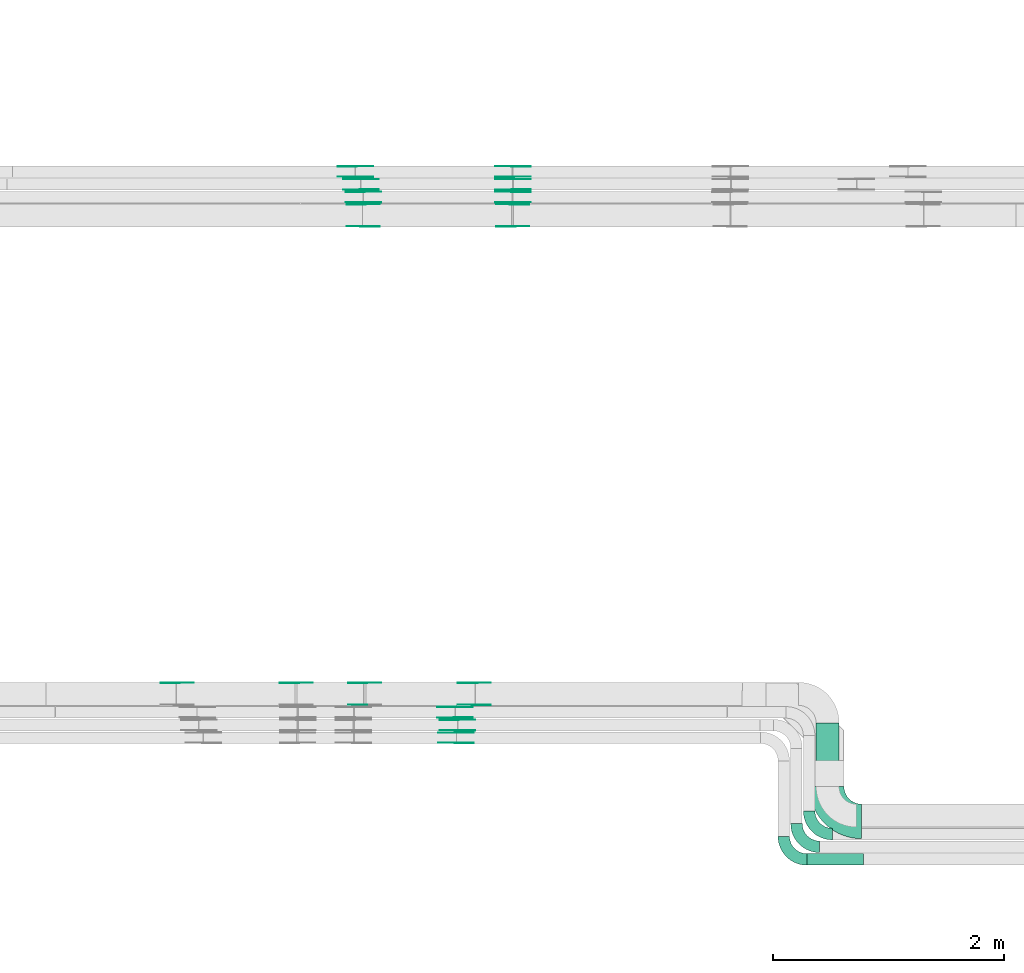
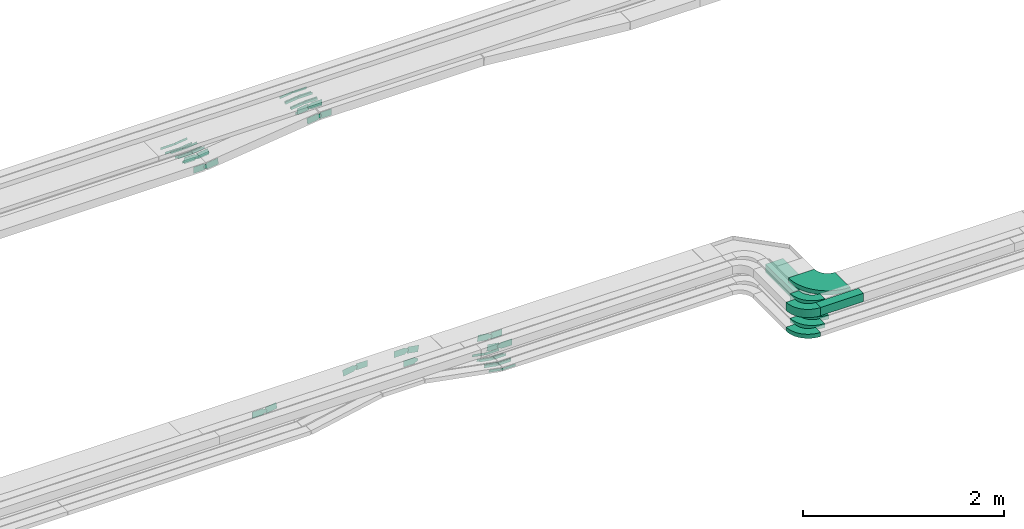
# One storey, part 22 of 33: 61 flow fittings, 2 flow segments.
"""IFC2X3 building model written with IfcOpenShell, lengths in millimetres."""

from ifc_helpers import new_model, entity, si_unit, converted_unit, derived_unit, direction, frame, frame_2d, origin, origin_2d_with_axis, place, context, subcontext, project, spatial, polyline, circle_curve, parameter, trimmed, segment, composite_curve, rectangle, outline, extrude, source, transform, mapped, material, type_object, type_shapes, element, save


model = new_model("IFC2X3")

# Units and contexts
model_context = context("Model", 3, precision=0.01, world=origin(), true_north=direction((6.12303176911189e-17, 1.0)))
body_context = subcontext(model_context, "Body", "Model", "MODEL_VIEW")
ifc_project = project(units=[si_unit("LENGTHUNIT", "METRE", prefix="MILLI"), si_unit("AREAUNIT", "SQUARE_METRE"), si_unit("VOLUMEUNIT", "CUBIC_METRE"), converted_unit("PLANEANGLEUNIT", "DEGREE", entity("IfcRatioMeasure", 0.0174532925199433), si_unit("PLANEANGLEUNIT", "RADIAN"), dimensions=[0, 0, 0, 0, 0, 0, 0]), si_unit("MASSUNIT", "GRAM", prefix="KILO"), derived_unit("MASSDENSITYUNIT", [(si_unit("MASSUNIT", "GRAM", prefix="KILO"), 1), (si_unit("LENGTHUNIT", "METRE"), -3)]), derived_unit("MOMENTOFINERTIAUNIT", [(si_unit("LENGTHUNIT", "METRE"), 4)]), si_unit("TIMEUNIT", "SECOND"), si_unit("FREQUENCYUNIT", "HERTZ"), si_unit("THERMODYNAMICTEMPERATUREUNIT", "DEGREE_CELSIUS"), derived_unit("THERMALTRANSMITTANCEUNIT", [(si_unit("MASSUNIT", "GRAM", prefix="KILO"), 1), (si_unit("THERMODYNAMICTEMPERATUREUNIT", "KELVIN"), -1), (si_unit("TIMEUNIT", "SECOND"), -3)]), derived_unit("VOLUMETRICFLOWRATEUNIT", [(si_unit("LENGTHUNIT", "METRE"), 3), (si_unit("TIMEUNIT", "SECOND"), -1)]), derived_unit("MASSFLOWRATEUNIT", [(si_unit("MASSUNIT", "GRAM", prefix="KILO"), 1), (si_unit("TIMEUNIT", "SECOND"), -1)]), derived_unit("ROTATIONALFREQUENCYUNIT", [(si_unit("TIMEUNIT", "SECOND"), -1)]), si_unit("ELECTRICCURRENTUNIT", "AMPERE"), si_unit("ELECTRICVOLTAGEUNIT", "VOLT"), si_unit("POWERUNIT", "WATT"), si_unit("FORCEUNIT", "NEWTON", prefix="KILO"), si_unit("ILLUMINANCEUNIT", "LUX"), si_unit("LUMINOUSFLUXUNIT", "LUMEN"), si_unit("LUMINOUSINTENSITYUNIT", "CANDELA"), derived_unit("USERDEFINED", [(si_unit("MASSUNIT", "GRAM", prefix="KILO"), -1), (si_unit("LENGTHUNIT", "METRE"), -2), (si_unit("TIMEUNIT", "SECOND"), 3), (si_unit("LUMINOUSFLUXUNIT", "LUMEN"), 1)]), derived_unit("LINEARVELOCITYUNIT", [(si_unit("LENGTHUNIT", "METRE"), 1), (si_unit("TIMEUNIT", "SECOND"), -1)]), si_unit("PRESSUREUNIT", "PASCAL"), derived_unit("USERDEFINED", [(si_unit("LENGTHUNIT", "METRE"), -2), (si_unit("MASSUNIT", "GRAM", prefix="KILO"), 1), (si_unit("TIMEUNIT", "SECOND"), -2)]), derived_unit("LINEARFORCEUNIT", [(si_unit("MASSUNIT", "GRAM", prefix="KILO"), 1), (si_unit("LENGTHUNIT", "METRE"), 1), (si_unit("TIMEUNIT", "SECOND"), -2), (si_unit("LENGTHUNIT", "METRE"), -1)]), derived_unit("PLANARFORCEUNIT", [(si_unit("MASSUNIT", "GRAM", prefix="KILO"), 1), (si_unit("LENGTHUNIT", "METRE"), 1), (si_unit("TIMEUNIT", "SECOND"), -2), (si_unit("LENGTHUNIT", "METRE"), -2)])], contexts=[model_context])

# Site, building, storey
site_placement = place(None, frame((0.0, -0.00077364408347762, 0.0)))
site = spatial("IfcSite", under=ifc_project, at=site_placement, CompositionType="ELEMENT")
building_placement = place(site_placement, origin())
building = spatial("IfcBuilding", under=site, at=building_placement, CompositionType="ELEMENT")
storey_placement = place(building_placement, frame((0.0, 0.0, 8100.0)))
storey = spatial("IfcBuildingStorey", under=building, at=storey_placement, CompositionType="ELEMENT", Elevation=8100.0)

# Flow segments
cable_carrier_segment_type = type_object("IfcCableCarrierSegmentType", PredefinedType="CABLETRAYSEGMENT")
flow_segment_1_placement = place(storey_placement, frame((55150.108534959, 9320.97860618819, 2549.83876380786)))
element("IfcFlowSegment", 1, at=flow_segment_1_placement, inside=storey, type_object=cable_carrier_segment_type, context=body_context, shape_type="SweptSolid", body=[
    extrude(rectangle(XDim=553.020769727205, YDim=200.000000000007, at=frame_2d((-1.10844666778576e-12, 0.0), x_axis=(1.0, 0.0))), frame((100.0, 276.510384863604, 0.0), z_axis=(0.0, 0.0, 1.0), x_axis=(0.0, 1.0, 0.0)), (0.0, 0.0, 1.0), 99.9999999999989),
])
flow_segment_2_placement = place(storey_placement, frame((55071.1085191337, 8639.97737136105, 2799.49164816939)))
element("IfcFlowSegment", 2, at=flow_segment_2_placement, inside=storey, type_object=cable_carrier_segment_type, context=body_context, shape_type="SweptSolid", body=[
    extrude(rectangle(XDim=489.621580336119, YDim=99.9999999999995, at=origin_2d_with_axis()), frame((244.810790168433, 50.0024377090797, 0.00129633967850395), z_axis=(3.16498725628962e-07, -2.43771475119288e-05, 1.0), x_axis=(-1.0, 0.0, 3.16498724808628e-07)), (0.0, 0.0, 1.0), 99.999999999998),
])

# Flow fittings
ifc_material_1 = material()
cable_carrier_fitting_type_1 = type_object("IfcCableCarrierFittingType", Name="470_DKC_S5_Variable Angle Elbow 0-45:-", PredefinedType="NOTDEFINED", material=ifc_material_1)
shared_shape_1 = source(origin(), body_context, "Body", "SweptSolid", [
    extrude(outline(composite_curve([segment(polyline([(-100.750000000001, -150.25), (-99.7499999999994, -150.25)]), True, "CONTINUOUS"), segment(trimmed(circle_curve(frame_2d((-99.7499999999997, 99.7499999999995), x_axis=(0.0, -1.0)), 250.0), [parameter(0.0)], [parameter(90.0000000000001)], True, "PARAMETER"), True, "CONTINUOUS"), segment(polyline([(150.25, 99.75), (150.25, 100.749999999999)]), True, "CONTINUOUS"), segment(polyline([(150.25, 100.749999999999), (50.25, 100.75)]), True, "CONTINUOUS"), segment(polyline([(50.25, 100.75), (50.25, 99.7499999999998)]), True, "CONTINUOUS"), segment(trimmed(circle_curve(frame_2d((-99.7499999999997, 99.7499999999995), x_axis=(0.0, -1.0)), 150.0), [parameter(0.0)], [parameter(90.0000000000001)], True, "PARAMETER"), False, "CONTINUOUS"), segment(polyline([(-99.7499999999994, -50.2500000000003), (-100.750000000001, -50.2500000000003)]), True, "CONTINUOUS"), segment(polyline([(-100.750000000001, -50.2500000000003), (-100.750000000001, -150.25)]), True, "CONTINUOUS")], self_intersect=False)), frame((-100.249999999991, 100.249999999992, -25.0)), (0.0, 0.0, 1.0), 49.9999999999997),
])
type_shapes(cable_carrier_fitting_type_1, [shared_shape_1])
for number, where, z_axis, x_axis, name in (
    (3, (55090.108534959, 8909.97860618824, 2574.87332137863), (0.0, 0.0, 1.0), (0.0, -1.0, 0.0), "470_DKC_S5_Variable Angle Elbow 0-45:-"),
    (4, (54980.108534959, 8799.97860618823, 2574.86934553524), (0.0, 0.0, 1.0), (0.0, -1.0, 0.0), "470_DKC_S5_Variable Angle Elbow 0-45:-"),
    (5, (54870.108534959, 8689.98005285079, 2573.15905189632), (0.0, 0.0, 1.0), (0.0, -1.0, 0.0), "470_DKC_S5_Variable Angle Elbow 0-45:-"),
):
    element("IfcFlowFitting", number, at=place(storey_placement, frame(where, z_axis=z_axis, x_axis=x_axis)), inside=storey, type_object=cable_carrier_fitting_type_1, material=ifc_material_1, Name=name, ObjectType="470_DKC_S5_Variable Angle Elbow 0-45:-", context=body_context, shape_type="MappedRepresentation", body=[
        mapped(shared_shape_1, transform((0.0, 0.0, 0.0), scale=1.0)),
    ])
ifc_material_2 = material(Name="G")
cable_carrier_fitting_type_2 = type_object("IfcCableCarrierFittingType", PredefinedType="NOTDEFINED", material=ifc_material_2)
shared_shape_2 = source(origin(), body_context, "Body", "SweptSolid", [
    extrude(outline(composite_curve([segment(trimmed(circle_curve(frame_2d((-44.5901162790698, 0.0), x_axis=(1.0, 0.0)), 12.5), [parameter(90.0000000000007)], [parameter(270.0)], True, "PARAMETER"), True, "CONTINUOUS"), segment(polyline([(-44.5901162790697, -12.5), (-33.0901162790698, -12.5)]), True, "CONTINUOUS"), segment(polyline([(-33.0901162790698, -12.5), (-31.2296511627907, -14.5)]), True, "CONTINUOUS"), segment(polyline([(-31.2296511627907, -14.5), (108.90988372093, -14.5)]), True, "CONTINUOUS"), segment(polyline([(108.90988372093, -14.5), (108.90988372093, 14.5)]), True, "CONTINUOUS"), segment(polyline([(108.90988372093, 14.5), (-31.2296511627907, 14.5)]), True, "CONTINUOUS"), segment(polyline([(-31.2296511627907, 14.5), (-33.0901162790698, 12.5)]), True, "CONTINUOUS"), segment(polyline([(-33.0901162790698, 12.5), (-44.5901162790699, 12.5)]), True, "CONTINUOUS")], self_intersect=False)), frame((44.5901162790698, 0.0, 0.0), z_axis=(0.0, 0.0, -1.0), x_axis=(1.0, 0.0, 0.0)), (0.0, 0.0, -1.0), 2.0),
])
type_shapes(cable_carrier_fitting_type_2, [shared_shape_2])
for number, where, z_axis, x_axis in (
    (6, (52019.5208098215, 10010.4593759256, 2574.8733213786), (0.0, 1.0, 0.0), (-0.98311633812243, 0.0, 0.182981599393884)),
    (7, (51155.4962064039, 14606.8182357371, 2573.86724903674), (0.0, -1.0, 0.0), (0.993566510793548, 0.0, 0.113250115362128)),
    (8, (51204.8808370864, 14587.7382357575, 2573.34838425104), (0.0, 1.0, 0.0), (-1.0, 0.0, 0.0)),
    (9, (51226.099251318, 14386.8182357372, 2573.879926104), (0.0, -1.0, 0.0), (0.992897734535639, 0.0, 0.118970957607288)),
    (10, (52520.9130823038, 14386.8182357372, 2729.02706365649), (0.0, -1.0, 0.0), (-0.992897734535639, 0.0, -0.118970957607288)),
    (11, (52520.9130823038, 14606.8182357371, 2729.50214316132), (0.0, -1.0, 0.0), (-0.993566510793548, 0.0, -0.113250115362128)),
    (12, (52522.9130823037, 14496.8182357372, 2729.0228574609), (0.0, -1.0, 0.0), (-0.993097003616873, 0.0, -0.117295956482691)),
    (13, (52040.1085349586, 9809.53937590527, 2575.03455757074), (0.0, -1.0, 0.0), (1.0, 0.0, -5.61945698194788e-05)),
    (14, (52030.1085349585, 9699.53937590527, 2573.32548188807), (0.0, -1.0, 0.0), (1.0, 0.0, -5.86021096785072e-05)),
):
    element("IfcFlowFitting", number, at=place(storey_placement, frame(where, z_axis=z_axis, x_axis=x_axis)), inside=storey, type_object=cable_carrier_fitting_type_2, material=ifc_material_2, context=body_context, shape_type="MappedRepresentation", body=[
        mapped(shared_shape_2, transform((0.0, 0.0, 0.0), scale=1.0)),
    ])
cable_carrier_fitting_type_3 = type_object("IfcCableCarrierFittingType", PredefinedType="NOTDEFINED", material=ifc_material_2)
shared_shape_3 = source(origin(), body_context, "Body", "SweptSolid", [
    extrude(outline(composite_curve([segment(trimmed(circle_curve(frame_2d((-44.5901162790697, 0.0), x_axis=(1.0, 0.0)), 12.5), [parameter(90.0000000000007)], [parameter(270.0)], True, "PARAMETER"), True, "CONTINUOUS"), segment(polyline([(-44.5901162790697, -12.5), (-33.0901162790697, -12.5)]), True, "CONTINUOUS"), segment(polyline([(-33.0901162790697, -12.5), (-31.2296511627907, -14.5)]), True, "CONTINUOUS"), segment(polyline([(-31.2296511627907, -14.5), (108.90988372093, -14.5)]), True, "CONTINUOUS"), segment(polyline([(108.90988372093, -14.5), (108.90988372093, 14.5)]), True, "CONTINUOUS"), segment(polyline([(108.90988372093, 14.5), (-31.2296511627907, 14.5)]), True, "CONTINUOUS"), segment(polyline([(-31.2296511627907, 14.5), (-33.0901162790698, 12.5)]), True, "CONTINUOUS"), segment(polyline([(-33.0901162790698, 12.5), (-44.5901162790699, 12.5)]), True, "CONTINUOUS")], self_intersect=False)), frame((44.5901162790697, 0.0, 0.0)), (0.0, 0.0, 1.0), 2.0),
])
type_shapes(cable_carrier_fitting_type_3, [shared_shape_3])
for number, where, z_axis, x_axis in (
    (15, (52019.5208098215, 9919.53937590525, 2574.8733213786), (0.0, -1.0, 0.0), (-0.98311633812243, 0.0, 0.182981599393884)),
    (16, (51155.4962064039, 14697.7382357574, 2573.86724903674), (0.0, 1.0, 0.0), (0.993566510793548, 0.0, 0.113250115362128)),
    (17, (51204.8808370864, 14496.8182357372, 2573.34838425103), (0.0, -1.0, 0.0), (-1.0, 0.0, 0.0)),
    (18, (51226.099251318, 14477.7382357575, 2573.87992610399), (0.0, 1.0, 0.0), (0.992897734535639, 0.0, 0.118970957607288)),
    (19, (52520.9130823038, 14477.7382357575, 2729.02706365649), (0.0, 1.0, 0.0), (-0.992897734535639, 0.0, -0.118970957607288)),
    (20, (52520.9130823038, 14697.7382357574, 2729.50214316132), (0.0, 1.0, 0.0), (-0.993566510793548, 0.0, -0.113250115362128)),
    (21, (52522.9130823037, 14587.7382357575, 2729.0228574609), (0.0, 1.0, 0.0), (-0.993097003616873, 0.0, -0.117295956482691)),
    (22, (52040.1085349586, 9900.45937592559, 2575.03455757074), (0.0, 1.0, 0.0), (1.0, 0.0, -5.61945698194788e-05)),
    (23, (52030.1085349585, 9790.45937592558, 2573.32548188807), (0.0, 1.0, 0.0), (1.0, 0.0, -5.86021096785072e-05)),
):
    element("IfcFlowFitting", number, at=place(storey_placement, frame(where, z_axis=z_axis, x_axis=x_axis)), inside=storey, type_object=cable_carrier_fitting_type_3, material=ifc_material_2, context=body_context, shape_type="MappedRepresentation", body=[
        mapped(shared_shape_3, transform((0.0, 0.0, 0.0), scale=1.0)),
    ])
cable_carrier_fitting_type_4 = type_object("IfcCableCarrierFittingType", PredefinedType="NOTDEFINED", material=ifc_material_2)
shared_shape_4 = source(origin(), body_context, "Body", "SweptSolid", [
    extrude(outline(composite_curve([segment(trimmed(circle_curve(frame_2d((-44.5901162790698, 0.0), x_axis=(1.0, 0.0)), 12.5), [parameter(90.0000000000007)], [parameter(270.0)], True, "PARAMETER"), True, "CONTINUOUS"), segment(polyline([(-44.5901162790697, -12.5), (-33.0901162790698, -12.5)]), True, "CONTINUOUS"), segment(polyline([(-33.0901162790698, -12.5), (-31.2296511627907, -14.5)]), True, "CONTINUOUS"), segment(polyline([(-31.2296511627907, -14.5), (108.90988372093, -14.5)]), True, "CONTINUOUS"), segment(polyline([(108.90988372093, -14.5), (108.90988372093, 14.5)]), True, "CONTINUOUS"), segment(polyline([(108.90988372093, 14.5), (-31.2296511627907, 14.5)]), True, "CONTINUOUS"), segment(polyline([(-31.2296511627907, 14.5), (-33.0901162790698, 12.5)]), True, "CONTINUOUS"), segment(polyline([(-33.0901162790698, 12.5), (-44.5901162790699, 12.5)]), True, "CONTINUOUS")], self_intersect=False)), frame((44.5901162790698, 0.0, 0.0), z_axis=(0.0, 0.0, -1.0), x_axis=(1.0, 0.0, 0.0)), (0.0, 0.0, -1.0), 2.0),
])
type_shapes(cable_carrier_fitting_type_4, [shared_shape_4])
for number, where, z_axis, x_axis in (
    (24, (52019.5208098215, 9921.53937590525, 2574.87332137861), (0.0, -1.0, 0.0), (1.0, 0.0, 0.0)),
    (25, (51155.4962064039, 14695.7382357574, 2573.86724903675), (0.0, 1.0, 0.0), (-1.0, 0.0, 0.0)),
    (26, (51204.8808370863, 14498.8182357372, 2573.34838425104), (0.0, -1.0, 0.0), (0.993097003616296, 0.0, 0.117295956487574)),
    (27, (51226.099251318, 14475.7382357575, 2573.879926104), (0.0, 1.0, 0.0), (-1.0, 0.0, 0.0)),
    (28, (52520.9130823038, 14475.7382357575, 2729.02706365649), (0.0, 1.0, 0.0), (1.0, 0.0, 0.0)),
    (29, (52520.9130823038, 14695.7382357574, 2729.50214316131), (0.0, 1.0, 0.0), (1.0, 0.0, 0.0)),
    (30, (52522.9130823037, 14585.7382357575, 2729.02285746089), (0.0, 1.0, 0.0), (1.0, 0.0, 0.0)),
    (31, (52040.1085349586, 9898.45937592559, 2575.03455757074), (0.0, 1.0, 0.0), (-0.983855320382267, 0.0, 0.178965663062799)),
    (32, (52030.1085349585, 9788.45937592558, 2573.32548188807), (0.0, 1.0, 0.0), (-0.983194962125338, 0.0, 0.182558665779952)),
):
    element("IfcFlowFitting", number, at=place(storey_placement, frame(where, z_axis=z_axis, x_axis=x_axis)), inside=storey, type_object=cable_carrier_fitting_type_4, material=ifc_material_2, context=body_context, shape_type="MappedRepresentation", body=[
        mapped(shared_shape_4, transform((0.0, 0.0, 0.0), scale=1.0)),
    ])
cable_carrier_fitting_type_5 = type_object("IfcCableCarrierFittingType", PredefinedType="NOTDEFINED", material=ifc_material_2)
shared_shape_5 = source(origin(), body_context, "Body", "SweptSolid", [
    extrude(outline(composite_curve([segment(trimmed(circle_curve(frame_2d((-44.5901162790697, 0.0), x_axis=(1.0, 0.0)), 12.5), [parameter(90.0000000000007)], [parameter(270.0)], True, "PARAMETER"), True, "CONTINUOUS"), segment(polyline([(-44.5901162790697, -12.5), (-33.0901162790697, -12.5)]), True, "CONTINUOUS"), segment(polyline([(-33.0901162790697, -12.5), (-31.2296511627907, -14.5)]), True, "CONTINUOUS"), segment(polyline([(-31.2296511627907, -14.5), (108.90988372093, -14.5)]), True, "CONTINUOUS"), segment(polyline([(108.90988372093, -14.5), (108.90988372093, 14.5)]), True, "CONTINUOUS"), segment(polyline([(108.90988372093, 14.5), (-31.2296511627907, 14.5)]), True, "CONTINUOUS"), segment(polyline([(-31.2296511627907, 14.5), (-33.0901162790698, 12.5)]), True, "CONTINUOUS"), segment(polyline([(-33.0901162790698, 12.5), (-44.5901162790699, 12.5)]), True, "CONTINUOUS")], self_intersect=False)), frame((44.5901162790697, 0.0, 0.0)), (0.0, 0.0, 1.0), 2.0),
])
type_shapes(cable_carrier_fitting_type_5, [shared_shape_5])
for number, where, z_axis, x_axis in (
    (33, (52019.5208098215, 10008.4593759256, 2574.87332137861), (0.0, 1.0, 0.0), (1.0, 0.0, 0.0)),
    (34, (51155.4962064039, 14608.8182357371, 2573.86724903675), (0.0, -1.0, 0.0), (-1.0, 0.0, 0.0)),
    (35, (51204.8808370863, 14585.7382357575, 2573.34838425104), (0.0, 1.0, 0.0), (0.993097003616296, 0.0, 0.117295956487574)),
    (36, (51226.099251318, 14388.8182357372, 2573.879926104), (0.0, -1.0, 0.0), (-1.0, 0.0, 0.0)),
    (37, (52520.9130823038, 14388.8182357372, 2729.02706365649), (0.0, -1.0, 0.0), (1.0, 0.0, 0.0)),
    (38, (52520.9130823038, 14608.8182357371, 2729.50214316131), (0.0, -1.0, 0.0), (1.0, 0.0, 0.0)),
    (39, (52522.9130823037, 14498.8182357372, 2729.02285746089), (0.0, -1.0, 0.0), (1.0, 0.0, 0.0)),
    (40, (52040.1085349586, 9811.53937590527, 2575.03455757075), (0.0, -1.0, 0.0), (-0.983855320382267, 0.0, 0.178965663062799)),
    (41, (52030.1085349585, 9701.53937590527, 2573.32548188807), (0.0, -1.0, 0.0), (-0.983194962125338, 0.0, 0.182558665779952)),
):
    element("IfcFlowFitting", number, at=place(storey_placement, frame(where, z_axis=z_axis, x_axis=x_axis)), inside=storey, type_object=cable_carrier_fitting_type_5, material=ifc_material_2, context=body_context, shape_type="MappedRepresentation", body=[
        mapped(shared_shape_5, transform((0.0, 0.0, 0.0), scale=1.0)),
    ])
cable_carrier_fitting_type_6 = type_object("IfcCableCarrierFittingType", PredefinedType="NOTDEFINED", material=ifc_material_2)
shared_shape_6 = source(origin(), body_context, "Body", "SweptSolid", [
    extrude(outline(composite_curve([segment(trimmed(circle_curve(frame_2d((-41.4651162790697, 0.0), x_axis=(1.0, 0.0)), 25.0), [parameter(90.0000000000007)], [parameter(270.0)], True, "PARAMETER"), True, "CONTINUOUS"), segment(polyline([(-41.4651162790697, -25.0), (-29.9651162790697, -25.0)]), True, "CONTINUOUS"), segment(polyline([(-29.9651162790697, -25.0), (-28.1046511627907, -38.5)]), True, "CONTINUOUS"), segment(polyline([(-28.1046511627907, -38.5), (99.5348837209303, -38.5)]), True, "CONTINUOUS"), segment(polyline([(99.5348837209303, -38.5), (99.5348837209303, 38.5)]), True, "CONTINUOUS"), segment(polyline([(99.5348837209303, 38.5), (-28.1046511627907, 38.5)]), True, "CONTINUOUS"), segment(polyline([(-28.1046511627907, 38.5), (-29.9651162790697, 25.0)]), True, "CONTINUOUS"), segment(polyline([(-29.9651162790697, 25.0), (-41.46511627907, 25.0)]), True, "CONTINUOUS")], self_intersect=False)), frame((41.4651162790697, 0.0, 0.0), z_axis=(0.0, 0.0, -1.0), x_axis=(1.0, 0.0, 0.0)), (0.0, 0.0, -1.0), 2.0),
])
type_shapes(cable_carrier_fitting_type_6, [shared_shape_6])
for number, where, z_axis, x_axis in (
    (42, (50645.658835578, 10220.4593759256, 2763.61173786447), (0.0, 1.0, 0.0), (1.0, 0.0, 0.0)),
    (43, (51233.9754297485, 10220.4593759256, 2763.61173786447), (0.0, 1.0, 0.0), (0.985679085688948, 0.0, -0.168631966232386)),
    (44, (51221.4706831692, 14179.0392263459, 2598.87698397098), (0.0, -1.0, 0.0), (0.992897734535631, 0.0, 0.118970957607356)),
    (45, (52520.9130823038, 14179.0392263459, 2754.57872565434), (0.0, -1.0, 0.0), (-0.992897734535631, 0.0, -0.118970957607356)),
    (46, (52190.1085349587, 10029.5393759052, 2600.03455757074), (0.0, -1.0, 0.0), (0.999999997952967, 0.0, -6.39848897058259e-05)),
):
    element("IfcFlowFitting", number, at=place(storey_placement, frame(where, z_axis=z_axis, x_axis=x_axis)), inside=storey, type_object=cable_carrier_fitting_type_6, material=ifc_material_2, context=body_context, shape_type="MappedRepresentation", body=[
        mapped(shared_shape_6, transform((0.0, 0.0, 0.0), scale=1.0)),
    ])
cable_carrier_fitting_type_7 = type_object("IfcCableCarrierFittingType", PredefinedType="NOTDEFINED", material=ifc_material_2)
shared_shape_7 = source(origin(), body_context, "Body", "SweptSolid", [
    extrude(outline(composite_curve([segment(trimmed(circle_curve(frame_2d((-41.4651162790697, 0.0), x_axis=(1.0, 0.0)), 25.0), [parameter(90.0000000000007)], [parameter(270.0)], True, "PARAMETER"), True, "CONTINUOUS"), segment(polyline([(-41.4651162790697, -25.0), (-29.9651162790697, -25.0)]), True, "CONTINUOUS"), segment(polyline([(-29.9651162790697, -25.0), (-28.1046511627907, -38.5)]), True, "CONTINUOUS"), segment(polyline([(-28.1046511627907, -38.5), (99.5348837209303, -38.5)]), True, "CONTINUOUS"), segment(polyline([(99.5348837209303, -38.5), (99.5348837209303, 38.5)]), True, "CONTINUOUS"), segment(polyline([(99.5348837209303, 38.5), (-28.1046511627907, 38.5)]), True, "CONTINUOUS"), segment(polyline([(-28.1046511627907, 38.5), (-29.9651162790697, 25.0)]), True, "CONTINUOUS"), segment(polyline([(-29.9651162790697, 25.0), (-41.46511627907, 25.0)]), True, "CONTINUOUS")], self_intersect=False)), frame((41.4651162790697, 0.0, 0.0)), (0.0, 0.0, 1.0), 2.0),
])
type_shapes(cable_carrier_fitting_type_7, [shared_shape_7])
for number, where, z_axis, x_axis in (
    (47, (49608.2757950546, 10220.4593759256, 2597.39498136106), (0.0, 1.0, 0.0), (0.987405642693208, 0.0, 0.15820902874872)),
    (48, (51221.4706831692, 14369.9592263662, 2598.87698397097), (0.0, 1.0, 0.0), (0.992897734535631, 0.0, 0.118970957607356)),
    (49, (52520.9130823038, 14369.9592263662, 2754.57872565435), (0.0, 1.0, 0.0), (-0.992897734535631, 0.0, -0.118970957607356)),
    (50, (52190.1085349587, 10220.4593759256, 2600.03455757074), (0.0, 1.0, 0.0), (0.999999997952967, 0.0, -6.39848897058259e-05)),
):
    element("IfcFlowFitting", number, at=place(storey_placement, frame(where, z_axis=z_axis, x_axis=x_axis)), inside=storey, type_object=cable_carrier_fitting_type_7, material=ifc_material_2, context=body_context, shape_type="MappedRepresentation", body=[
        mapped(shared_shape_7, transform((0.0, 0.0, 0.0), scale=1.0)),
    ])
cable_carrier_fitting_type_8 = type_object("IfcCableCarrierFittingType", PredefinedType="NOTDEFINED", material=ifc_material_2)
shared_shape_8 = source(origin(), body_context, "Body", "SweptSolid", [
    extrude(outline(composite_curve([segment(trimmed(circle_curve(frame_2d((-41.4651162790697, 0.0), x_axis=(1.0, 0.0)), 25.0), [parameter(90.0000000000007)], [parameter(270.0)], True, "PARAMETER"), True, "CONTINUOUS"), segment(polyline([(-41.4651162790697, -25.0), (-29.9651162790697, -25.0)]), True, "CONTINUOUS"), segment(polyline([(-29.9651162790697, -25.0), (-28.1046511627907, -38.5)]), True, "CONTINUOUS"), segment(polyline([(-28.1046511627907, -38.5), (99.5348837209303, -38.5)]), True, "CONTINUOUS"), segment(polyline([(99.5348837209303, -38.5), (99.5348837209303, 38.5)]), True, "CONTINUOUS"), segment(polyline([(99.5348837209303, 38.5), (-28.1046511627907, 38.5)]), True, "CONTINUOUS"), segment(polyline([(-28.1046511627907, 38.5), (-29.9651162790697, 25.0)]), True, "CONTINUOUS"), segment(polyline([(-29.9651162790697, 25.0), (-41.46511627907, 25.0)]), True, "CONTINUOUS")], self_intersect=False)), frame((41.4651162790697, 0.0, 0.0), z_axis=(0.0, 0.0, -1.0), x_axis=(1.0, 0.0, 0.0)), (0.0, 0.0, -1.0), 2.0),
])
type_shapes(cable_carrier_fitting_type_8, [shared_shape_8])
for number, where, z_axis, x_axis in (
    (51, (49608.2757950546, 10218.4593759256, 2597.39498136107), (0.0, 1.0, 0.0), (-1.0, 0.0, 0.0)),
    (52, (51233.9754297485, 10031.5393759052, 2763.61173786446), (0.0, -1.0, 0.0), (-1.0, 0.0, 0.0)),
    (53, (51221.4706831692, 14367.9592263662, 2598.87698397098), (0.0, 1.0, 0.0), (-1.0, 0.0, 0.0)),
    (54, (52520.9130823038, 14367.9592263662, 2754.57872565434), (0.0, 1.0, 0.0), (1.0, 0.0, 0.0)),
    (55, (52190.1085349587, 10218.4593759256, 2600.03455757074), (0.0, 1.0, 0.0), (-0.985679085688951, 0.0, 0.168631966232368)),
):
    element("IfcFlowFitting", number, at=place(storey_placement, frame(where, z_axis=z_axis, x_axis=x_axis)), inside=storey, type_object=cable_carrier_fitting_type_8, material=ifc_material_2, context=body_context, shape_type="MappedRepresentation", body=[
        mapped(shared_shape_8, transform((0.0, 0.0, 0.0), scale=1.0)),
    ])
cable_carrier_fitting_type_9 = type_object("IfcCableCarrierFittingType", PredefinedType="NOTDEFINED", material=ifc_material_2)
shared_shape_9 = source(origin(), body_context, "Body", "SweptSolid", [
    extrude(outline(composite_curve([segment(trimmed(circle_curve(frame_2d((-41.4651162790697, 0.0), x_axis=(1.0, 0.0)), 25.0), [parameter(90.0000000000007)], [parameter(270.0)], True, "PARAMETER"), True, "CONTINUOUS"), segment(polyline([(-41.4651162790697, -25.0), (-29.9651162790697, -25.0)]), True, "CONTINUOUS"), segment(polyline([(-29.9651162790697, -25.0), (-28.1046511627907, -38.5)]), True, "CONTINUOUS"), segment(polyline([(-28.1046511627907, -38.5), (99.5348837209303, -38.5)]), True, "CONTINUOUS"), segment(polyline([(99.5348837209303, -38.5), (99.5348837209303, 38.5)]), True, "CONTINUOUS"), segment(polyline([(99.5348837209303, 38.5), (-28.1046511627907, 38.5)]), True, "CONTINUOUS"), segment(polyline([(-28.1046511627907, 38.5), (-29.9651162790697, 25.0)]), True, "CONTINUOUS"), segment(polyline([(-29.9651162790697, 25.0), (-41.46511627907, 25.0)]), True, "CONTINUOUS")], self_intersect=False)), frame((41.4651162790697, 0.0, 0.0)), (0.0, 0.0, 1.0), 2.0),
])
type_shapes(cable_carrier_fitting_type_9, [shared_shape_9])
for number, where, z_axis, x_axis in (
    (56, (50645.658835578, 10218.4593759255, 2763.61173786447), (0.0, 1.0, 0.0), (-0.987405642693216, 0.0, -0.158209028748672)),
    (57, (51233.9754297485, 10218.4593759255, 2763.61173786446), (0.0, 1.0, 0.0), (-1.0, 0.0, 0.0)),
    (58, (51221.4706831692, 14181.0392263459, 2598.87698397098), (0.0, -1.0, 0.0), (-1.0, 0.0, 0.0)),
    (59, (52520.9130823038, 14181.0392263459, 2754.57872565434), (0.0, -1.0, 0.0), (1.0, 0.0, 0.0)),
    (60, (52190.1085349587, 10031.5393759052, 2600.03455757074), (0.0, -1.0, 0.0), (-0.985679085688951, 0.0, 0.168631966232368)),
):
    element("IfcFlowFitting", number, at=place(storey_placement, frame(where, z_axis=z_axis, x_axis=x_axis)), inside=storey, type_object=cable_carrier_fitting_type_9, material=ifc_material_2, context=body_context, shape_type="MappedRepresentation", body=[
        mapped(shared_shape_9, transform((0.0, 0.0, 0.0), scale=1.0)),
    ])
cable_carrier_fitting_type_10 = type_object("IfcCableCarrierFittingType", Name="470_DKC_S5_Variable Angle Elbow 0-45:-", PredefinedType="NOTDEFINED", material=ifc_material_1)
shared_shape_10 = source(origin(), body_context, "Body", "SweptSolid", [
    extrude(outline(composite_curve([segment(polyline([(-150.750169545514, -300.107871755739), (-149.750169545513, -300.107871755739)]), True, "CONTINUOUS"), segment(trimmed(circle_curve(frame_2d((-149.750169545521, 149.892128244261), x_axis=(0.0, -1.0)), 450.0), [parameter(0.0)], [parameter(89.9457110444371)], True, "PARAMETER"), True, "CONTINUOUS"), segment(polyline([(300.249628450374, 149.465743848151), (300.250575971254, 150.465743399251)]), True, "CONTINUOUS"), segment(polyline([(300.250575971254, 150.465743399251), (0.250710640657538, 150.749999663328)]), True, "CONTINUOUS"), segment(polyline([(0.250710640657566, 150.749999663328), (0.249763119777295, 149.750000112224)]), True, "CONTINUOUS"), segment(trimmed(circle_curve(frame_2d((-149.750169545521, 149.892128244261), x_axis=(0.0, -1.0)), 150.0), [parameter(0.0)], [parameter(89.9457110444371)], True, "PARAMETER"), False, "CONTINUOUS"), segment(polyline([(-149.750169545518, -0.107871755738903), (-150.750169545519, -0.10787175573892)]), True, "CONTINUOUS"), segment(polyline([(-150.750169545519, -0.10787175573892), (-150.750169545514, -300.107871755739)]), True, "CONTINUOUS")], self_intersect=False)), frame((-149.965708732254, 150.107871755728, -25.0)), (0.0, 0.0, 1.0), 49.9999999999974),
])
type_shapes(cable_carrier_fitting_type_10, [shared_shape_10])
flow_fitting_placement = place(storey_placement, frame((55242.8444336607, 9019.97860618828, 2813.91979567565), z_axis=(0.0, -0.000610279574786019, 0.999999813779403), x_axis=(0.000947520880263047, -0.999999364881477, -0.000610279300832732)))
element("IfcFlowFitting", 61, at=flow_fitting_placement, inside=storey, type_object=cable_carrier_fitting_type_10, material=ifc_material_1, Name="470_DKC_S5_Variable Angle Elbow 0-45:-", ObjectType="470_DKC_S5_Variable Angle Elbow 0-45:-", context=body_context, shape_type="MappedRepresentation", body=[
    mapped(shared_shape_10, transform((0.0, 0.0, 0.0), scale=1.0)),
])
cable_carrier_fitting_type_11 = type_object("IfcCableCarrierFittingType", Name="470_DKC_S5_Variable Angle Elbow 0-45:-", PredefinedType="NOTDEFINED", material=ifc_material_1)
shared_shape_11 = source(origin(), body_context, "Body", "SweptSolid", [
    extrude(outline(composite_curve([segment(polyline([(-100.749999999999, -150.250000000001), (-99.7499999999981, -150.250000000001)]), True, "CONTINUOUS"), segment(trimmed(circle_curve(frame_2d((-99.7500000000006, 99.7499999999987), x_axis=(0.0, -1.0)), 250.0), [parameter(0.0)], [parameter(90.0000000000001)], True, "PARAMETER"), True, "CONTINUOUS"), segment(polyline([(150.249999999999, 99.7500000000013), (150.249999999999, 100.750000000001)]), True, "CONTINUOUS"), segment(polyline([(150.249999999999, 100.750000000001), (50.2499999999992, 100.750000000001)]), True, "CONTINUOUS"), segment(polyline([(50.2499999999992, 100.750000000001), (50.2499999999992, 99.7500000000002)]), True, "CONTINUOUS"), segment(trimmed(circle_curve(frame_2d((-99.7500000000006, 99.7499999999987), x_axis=(0.0, -1.0)), 150.0), [parameter(0.0)], [parameter(90.0000000000001)], True, "PARAMETER"), False, "CONTINUOUS"), segment(polyline([(-99.7499999999989, -50.2500000000011), (-100.75, -50.2500000000011)]), True, "CONTINUOUS"), segment(polyline([(-100.75, -50.2500000000011), (-100.749999999999, -150.250000000001)]), True, "CONTINUOUS")], self_intersect=False)), frame((-100.249999999991, 100.249999999992, -50.0)), (0.0, 0.0, 1.0), 100.0),
])
type_shapes(cable_carrier_fitting_type_11, [shared_shape_11])
for number, where, z_axis, x_axis, name in (
    (62, (54870.1085349591, 8689.97859020358, 2849.49308559275), (3.16498718168883e-07, 0.00020483524637321, 0.999999979021211), (0.0, -0.999999979021261, 0.000204835246373221), "470_DKC_S5_Variable Angle Elbow 0-45:-"),
    (63, (54980.3347331043, 8799.97860603509, 2850.01942404382), (8.83740159515312e-07, 0.000204778842238923, 0.999999979032422), (0.0, -0.999999979032813, 0.000204778842239003), "470_DKC_S5_Variable Angle Elbow 0-45:-"),
):
    element("IfcFlowFitting", number, at=place(storey_placement, frame(where, z_axis=z_axis, x_axis=x_axis)), inside=storey, type_object=cable_carrier_fitting_type_11, material=ifc_material_1, Name=name, ObjectType="470_DKC_S5_Variable Angle Elbow 0-45:-", context=body_context, shape_type="MappedRepresentation", body=[
        mapped(shared_shape_11, transform((0.0, 0.0, 0.0), scale=1.0)),
    ])

save(model, "model.ifc")
